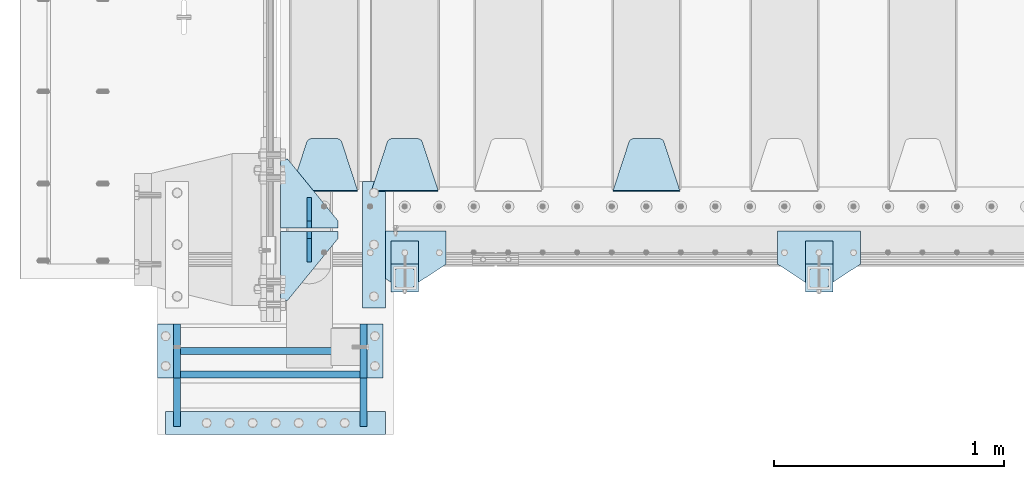
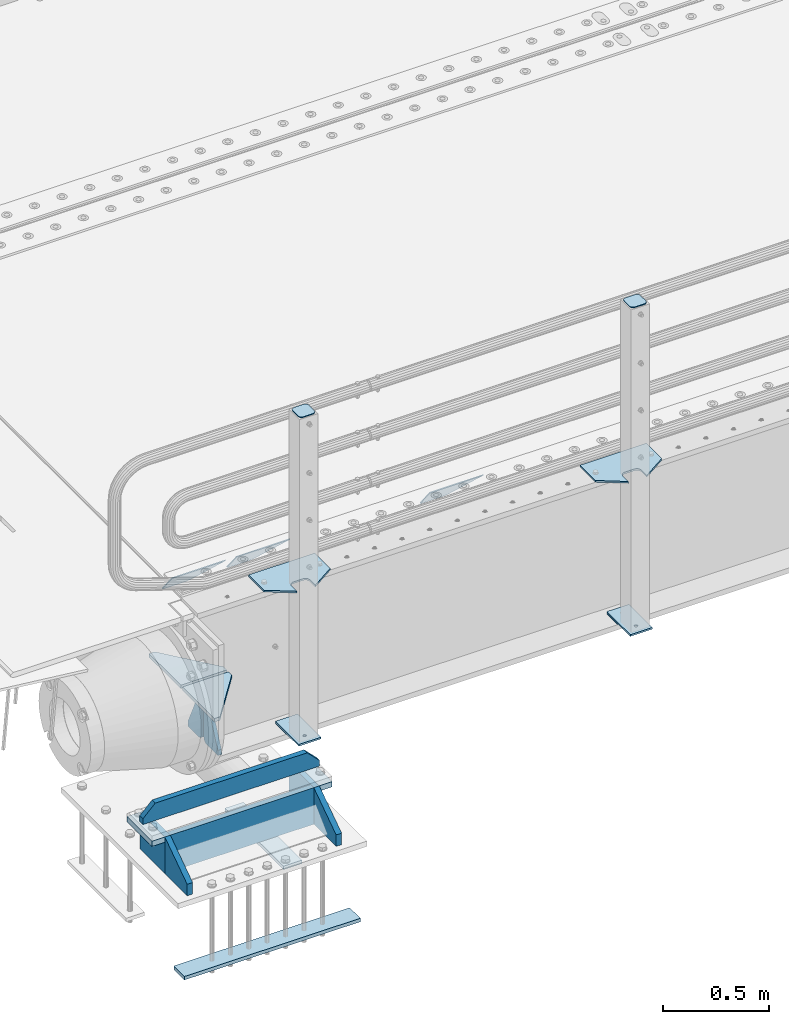
# One storey, part 154 of 193: 25 plates.
"""IFC2X3 building model written with IfcOpenShell, lengths in millimetres."""

from ifc_helpers import new_model, si_unit, frame, origin_with_axes, place, context, subcontext, project, spatial, faceted_brep, material, type_object, element, save


model = new_model("IFC2X3")

# Units and contexts
model_context = context("Model", 3, precision=1e-05, world=origin_with_axes())
body_context = subcontext(model_context, "Body", "Model", "MODEL_VIEW")
ifc_project = project(units=[si_unit("LENGTHUNIT", "METRE", prefix="MILLI"), si_unit("AREAUNIT", "SQUARE_METRE"), si_unit("VOLUMEUNIT", "CUBIC_METRE"), si_unit("MASSUNIT", "GRAM", prefix="KILO"), si_unit("TIMEUNIT", "SECOND"), si_unit("PLANEANGLEUNIT", "RADIAN"), si_unit("SOLIDANGLEUNIT", "STERADIAN"), si_unit("THERMODYNAMICTEMPERATUREUNIT", "DEGREE_CELSIUS"), si_unit("LUMINOUSINTENSITYUNIT", "LUMEN")], contexts=[model_context])

# Site, building, storey
site_placement = place(None, origin_with_axes())
site = spatial("IfcSite", under=ifc_project, at=site_placement, CompositionType="ELEMENT")
building_placement = place(site_placement, origin_with_axes())
building = spatial("IfcBuilding", under=site, at=building_placement, Name="Standard", CompositionType="ELEMENT")
storey_placement = place(building_placement, origin_with_axes())
storey = spatial("IfcBuildingStorey", under=building, at=storey_placement, Name="Undefined", CompositionType="ELEMENT", Elevation=0.0)

# Plates
ifc_material_1 = material(Name="STEEL/S355N")
plate_type_1 = type_object("IfcPlateType", PredefinedType="NOTDEFINED")
plate_1_placement = place(storey_placement, frame((-40705.0, 24168.232233047, -1.76776695296758), z_axis=(0.0, 0.707106781186547, -0.707106781186548), x_axis=(-1.0, 0.0, 0.0)))
element("IfcPlate", 1, at=plate_1_placement, inside=storey, type_object=plate_type_1, material=ifc_material_1, context=body_context, shape_type="Brep", body=[
    faceted_brep([(0.0, -2.5, 0.0), (69.345504679477, -2.50000000000364, 300.171731424831), (69.345504679477, 2.49999999999636, 300.171731424831), (0.0, 2.5, 0.0), (70.9274061199576, -2.50000000000364, 304.897442415397), (70.9274061199576, 2.49999999999636, 304.897442415397), (73.3818627772307, -2.50000000000364, 309.234538108529), (73.3818627772307, 2.49999999999636, 309.234538108529), (76.6187032999551, -2.50000000000728, 313.023683126103), (76.6187032999551, 2.49999999999636, 313.023683126103), (80.5190132704993, -2.50000000000364, 316.125672595372), (80.5190132704993, 2.49999999999636, 316.125672595368), (84.9395038596849, -2.50000000000364, 318.426546230472), (84.9395038596849, 2.49999999999636, 318.426546230476), (89.7177759439219, -2.50000000000364, 319.841774983273), (89.7177759439219, 2.49999999999636, 319.841774983277), (94.678286292652, -2.50000000000364, 320.319366455074), (94.678286292652, 2.49999999999636, 320.319366455074), (195.321713707348, -2.50000000000364, 320.319366455074), (195.321713707348, 2.49999999999636, 320.319366455074), (200.282224056078, -2.50000000000364, 319.841774983273), (200.282224056078, 2.49999999999636, 319.841774983277), (205.060496140315, -2.50000000000364, 318.426546230472), (205.060496140315, 2.49999999999636, 318.426546230472), (209.480986729501, -2.50000000000364, 316.125672595372), (209.480986729501, 2.49999999999636, 316.125672595368), (213.381296700045, -2.50000000000728, 313.023683126103), (213.381296700045, 2.49999999999272, 313.023683126103), (216.618137222769, -2.50000000000364, 309.234538108525), (216.618137222769, 2.49999999999636, 309.234538108522), (219.072593880042, -2.50000000000364, 304.897442415397), (219.072593880042, 2.49999999999636, 304.897442415397), (220.654495320523, -2.50000000000364, 300.171731424831), (220.654495320523, 2.49999999999636, 300.171731424831), (290.0, -2.50000000000364, 0.0), (290.0, 2.49999999999636, 0.0)], [[[0, 1, 2, 3]], [[1, 4, 5, 2]], [[4, 6, 7, 5]], [[6, 8, 9, 7]], [[8, 10, 11, 9]], [[10, 12, 13, 11]], [[12, 14, 15, 13]], [[14, 16, 17, 15]], [[16, 18, 19, 17]], [[18, 20, 21, 19]], [[20, 22, 23, 21]], [[22, 24, 25, 23]], [[24, 26, 27, 25]], [[26, 28, 29, 27]], [[28, 30, 31, 29]], [[30, 32, 33, 31]], [[32, 34, 35, 33]], [[34, 0, 3, 35]], [[5, 7, 9, 11, 13, 15, 17, 19, 21, 23, 25, 27, 29, 31, 33, 35, 3, 2]], [[34, 32, 30, 28, 26, 24, 22, 20, 18, 16, 14, 12, 10, 8, 6, 4, 1, 0]]]),
])
plate_2_placement = place(storey_placement, frame((-41755.0, 24168.232233047, -1.76776695296758), z_axis=(0.0, 0.707106781186547, -0.707106781186548), x_axis=(-1.0, 0.0, 0.0)))
element("IfcPlate", 2, at=plate_2_placement, inside=storey, type_object=plate_type_1, material=ifc_material_1, context=body_context, shape_type="Brep", body=[
    faceted_brep([(0.0, -2.5, 0.0), (69.345504679477, -2.50000000000364, 300.171731424831), (69.345504679477, 2.49999999999636, 300.171731424831), (0.0, 2.5, 0.0), (70.9274061199576, -2.50000000000364, 304.897442415397), (70.9274061199576, 2.49999999999636, 304.897442415397), (73.3818627772307, -2.50000000000364, 309.234538108529), (73.3818627772307, 2.49999999999636, 309.234538108529), (76.6187032999551, -2.50000000000728, 313.023683126103), (76.6187032999551, 2.49999999999636, 313.023683126103), (80.5190132704993, -2.50000000000364, 316.125672595372), (80.5190132704993, 2.49999999999636, 316.125672595368), (84.9395038596849, -2.50000000000364, 318.426546230472), (84.9395038596849, 2.49999999999636, 318.426546230476), (89.7177759439219, -2.50000000000364, 319.841774983273), (89.7177759439219, 2.49999999999636, 319.841774983277), (94.678286292652, -2.50000000000364, 320.319366455074), (94.678286292652, 2.49999999999636, 320.319366455074), (195.321713707348, -2.50000000000364, 320.319366455074), (195.321713707348, 2.49999999999636, 320.319366455074), (200.282224056078, -2.50000000000364, 319.841774983273), (200.282224056078, 2.49999999999636, 319.841774983277), (205.060496140315, -2.50000000000364, 318.426546230472), (205.060496140315, 2.49999999999636, 318.426546230472), (209.480986729501, -2.50000000000364, 316.125672595372), (209.480986729501, 2.49999999999636, 316.125672595368), (213.381296700045, -2.50000000000728, 313.023683126103), (213.381296700045, 2.49999999999272, 313.023683126103), (216.618137222769, -2.50000000000364, 309.234538108525), (216.618137222769, 2.49999999999636, 309.234538108522), (219.072593880042, -2.50000000000364, 304.897442415397), (219.072593880042, 2.49999999999636, 304.897442415397), (220.654495320523, -2.50000000000364, 300.171731424831), (220.654495320523, 2.49999999999636, 300.171731424831), (290.0, -2.50000000000364, 0.0), (290.0, 2.49999999999636, 0.0)], [[[0, 1, 2, 3]], [[1, 4, 5, 2]], [[4, 6, 7, 5]], [[6, 8, 9, 7]], [[8, 10, 11, 9]], [[10, 12, 13, 11]], [[12, 14, 15, 13]], [[14, 16, 17, 15]], [[16, 18, 19, 17]], [[18, 20, 21, 19]], [[20, 22, 23, 21]], [[22, 24, 25, 23]], [[24, 26, 27, 25]], [[26, 28, 29, 27]], [[28, 30, 31, 29]], [[30, 32, 33, 31]], [[32, 34, 35, 33]], [[34, 0, 3, 35]], [[5, 7, 9, 11, 13, 15, 17, 19, 21, 23, 25, 27, 29, 31, 33, 35, 3, 2]], [[34, 32, 30, 28, 26, 24, 22, 20, 18, 16, 14, 12, 10, 8, 6, 4, 1, 0]]]),
])
plate_3_placement = place(storey_placement, frame((-42105.0, 24168.232233047, -1.76776695296758), z_axis=(0.0, 0.707106781186547, -0.707106781186548), x_axis=(-1.0, 0.0, 0.0)))
element("IfcPlate", 3, at=plate_3_placement, inside=storey, type_object=plate_type_1, material=ifc_material_1, context=body_context, shape_type="Brep", body=[
    faceted_brep([(0.0, -2.5, 0.0), (69.345504679477, -2.50000000000364, 300.171731424831), (69.345504679477, 2.49999999999636, 300.171731424831), (0.0, 2.5, 0.0), (70.9274061199576, -2.50000000000364, 304.897442415397), (70.9274061199576, 2.49999999999636, 304.897442415397), (73.3818627772307, -2.50000000000364, 309.234538108529), (73.3818627772307, 2.49999999999636, 309.234538108529), (76.6187032999551, -2.50000000000728, 313.023683126103), (76.6187032999551, 2.49999999999636, 313.023683126103), (80.5190132704993, -2.50000000000364, 316.125672595372), (80.5190132704993, 2.49999999999636, 316.125672595368), (84.9395038596849, -2.50000000000364, 318.426546230472), (84.9395038596849, 2.49999999999636, 318.426546230476), (89.7177759439219, -2.50000000000364, 319.841774983273), (89.7177759439219, 2.49999999999636, 319.841774983277), (94.678286292652, -2.50000000000364, 320.319366455074), (94.678286292652, 2.49999999999636, 320.319366455074), (195.321713707348, -2.50000000000364, 320.319366455074), (195.321713707348, 2.49999999999636, 320.319366455074), (200.282224056078, -2.50000000000364, 319.841774983273), (200.282224056078, 2.49999999999636, 319.841774983277), (205.060496140315, -2.50000000000364, 318.426546230472), (205.060496140315, 2.49999999999636, 318.426546230472), (209.480986729501, -2.50000000000364, 316.125672595372), (209.480986729501, 2.49999999999636, 316.125672595368), (213.381296700045, -2.50000000000728, 313.023683126103), (213.381296700045, 2.49999999999272, 313.023683126103), (216.618137222769, -2.50000000000364, 309.234538108525), (216.618137222769, 2.49999999999636, 309.234538108522), (219.072593880042, -2.50000000000364, 304.897442415397), (219.072593880042, 2.49999999999636, 304.897442415397), (220.654495320523, -2.50000000000364, 300.171731424831), (220.654495320523, 2.49999999999636, 300.171731424831), (290.0, -2.50000000000364, 0.0), (290.0, 2.49999999999636, 0.0)], [[[0, 1, 2, 3]], [[1, 4, 5, 2]], [[4, 6, 7, 5]], [[6, 8, 9, 7]], [[8, 10, 11, 9]], [[10, 12, 13, 11]], [[12, 14, 15, 13]], [[14, 16, 17, 15]], [[16, 18, 19, 17]], [[18, 20, 21, 19]], [[20, 22, 23, 21]], [[22, 24, 25, 23]], [[24, 26, 27, 25]], [[26, 28, 29, 27]], [[28, 30, 31, 29]], [[30, 32, 33, 31]], [[32, 34, 35, 33]], [[34, 0, 3, 35]], [[5, 7, 9, 11, 13, 15, 17, 19, 21, 23, 25, 27, 29, 31, 33, 35, 3, 2]], [[34, 32, 30, 28, 26, 24, 22, 20, 18, 16, 14, 12, 10, 8, 6, 4, 1, 0]]]),
])
plate_type_2 = type_object("IfcPlateType", PredefinedType="NOTDEFINED")
for number, where, z_axis, x_axis in (
    (4, (-42190.0, 24008.0, -515.0), (0.0, 1.0, 0.0), (-1.0, 0.0, 0.0)),
    (5, (-42190.0, 23992.0, -515.0), (0.0, -1.0, 0.0), (-1.0, 0.0, 0.0)),
):
    element("IfcPlate", number, at=place(storey_placement, frame(where, z_axis=z_axis, x_axis=x_axis)), inside=storey, type_object=plate_type_2, material=ifc_material_1, context=body_context, shape_type="Brep", body=[
        faceted_brep([(0.0, -10.0, 0.0), (0.0, -10.0, 30.0), (0.0, 10.0, 30.0), (0.0, 10.0, 0.0), (220.0, -10.0, 300.0), (220.0, 10.0, 300.0), (250.0, -10.0, 300.0), (250.0, 10.0, 300.0), (250.0, -10.0, 0.0), (250.0, 10.0, 0.0)], [[[0, 1, 2, 3]], [[1, 4, 5, 2]], [[4, 6, 7, 5]], [[6, 8, 9, 7]], [[8, 0, 3, 9]], [[5, 7, 9, 3, 2]], [[8, 6, 4, 1, 0]]]),
    ])
plate_type_3 = type_object("IfcPlateType", PredefinedType="NOTDEFINED")
for number, where, z_axis, x_axis in (
    (6, (-42315.0, 23860.0, -860.0), (0.0, 0.0, 1.0), (0.0, 1.0, 0.0)),
    (7, (-42315.0, 24140.0, -860.0), (0.0, 0.0, 1.0), (0.0, -1.0, 0.0)),
):
    element("IfcPlate", number, at=place(storey_placement, frame(where, z_axis=z_axis, x_axis=x_axis)), inside=storey, type_object=plate_type_3, material=ifc_material_1, context=body_context, shape_type="Brep", body=[
        faceted_brep([(0.0, -10.0, 0.0), (0.0, -10.0, 30.0), (0.0, 10.0, 30.0), (0.0, 10.0, 0.0), (102.0, -10.0, 250.0), (102.0, 10.0, 250.0), (132.0, -10.0, 250.0), (132.0, 10.0, 250.0), (132.0, -10.0, 30.0), (132.0, 10.0, 30.0), (131.544232590368, -10.0, 24.790554669992), (131.544232590368, 10.0, 24.790554669992), (130.190778623579, -10.0, 19.7393957002299), (130.190778623579, 10.0, 19.7393957002299), (127.980762113533, -10.0, 15.0), (127.980762113533, 10.0, 15.0), (124.98133329357, -10.0, 10.7163717094038), (124.98133329357, 10.0, 10.7163717094038), (121.283628290596, -10.0, 7.01866670643062), (121.283628290596, 10.0, 7.01866670643062), (117.0, -10.0, 4.01923788646684), (117.0, 10.0, 4.01923788646684), (112.260604299769, -10.0, 1.80922137642278), (112.260604299769, 10.0, 1.80922137642278), (107.209445330009, -10.0, 0.455767409633722), (107.209445330009, 10.0, 0.455767409633722), (102.0, -10.0, 0.0), (102.0, 10.0, 0.0)], [[[0, 1, 2, 3]], [[1, 4, 5, 2]], [[4, 6, 7, 5]], [[6, 8, 9, 7]], [[8, 10, 11, 9]], [[10, 12, 13, 11]], [[12, 14, 15, 13]], [[14, 16, 17, 15]], [[16, 18, 19, 17]], [[18, 20, 21, 19]], [[20, 22, 23, 21]], [[22, 24, 25, 23]], [[24, 26, 27, 25]], [[26, 0, 3, 27]], [[5, 7, 9, 11, 13, 15, 17, 19, 21, 23, 25, 27, 3, 2]], [[26, 24, 22, 20, 18, 16, 14, 12, 10, 8, 6, 4, 1, 0]]]),
    ])
ifc_material_2 = material(Name="STEEL/S355J2")
plate_type_4 = type_object("IfcPlateType", PredefinedType="NOTDEFINED")
plate_4_placement = place(storey_placement, frame((-39920.0, 23995.0, 5.00000000004911), z_axis=(0.0, -1.0, 0.0), x_axis=(-1.0, 0.0, 0.0)))
element("IfcPlate", 8, at=plate_4_placement, inside=storey, type_object=plate_type_4, material=ifc_material_2, context=body_context, shape_type="Brep", body=[
    faceted_brep([(0.0, -5.0, 0.0), (2.31396552408114e-06, -5.0, 145.0), (2.31396552408114e-06, 5.0, 145.0), (0.0, 5.0, 0.0), (130.0, -5.0, 230.0), (130.0, 5.0, 230.0), (130.0, -5.0, 180.0), (130.0, 5.0, 180.0), (130.48036798992, -5.0, 175.122741949595), (130.48036798992, 5.0, 175.122741949595), (131.903011687216, -5.0, 170.432914190871), (131.903011687216, 5.0, 170.432914190871), (134.213259692435, -5.0, 166.110744174512), (134.213259692435, 5.0, 166.110744174512), (137.322330470335, -5.0, 162.322330470335), (137.322330470335, 5.0, 162.322330470335), (141.110744174512, -5.0, 159.213259692435), (141.110744174512, 5.0, 159.213259692435), (145.432914190871, -5.0, 156.903011687216), (145.432914190871, 5.0, 156.903011687216), (150.122741949595, -5.0, 155.48036798992), (150.122741949595, 5.0, 155.48036798992), (155.0, -5.0, 155.0), (155.0, 5.0, 155.0), (205.0, -5.0, 155.0), (205.0, 5.0, 155.0), (209.877258050405, -5.0, 155.48036798992), (209.877258050405, 5.0, 155.48036798992), (214.567085809129, -5.0, 156.903011687216), (214.567085809129, 5.0, 156.903011687216), (218.889255825488, -5.0, 159.213259692435), (218.889255825488, 5.0, 159.213259692435), (222.677669529665, -5.0, 162.322330470335), (222.677669529665, 5.0, 162.322330470335), (225.786740307565, -5.0, 166.110744174512), (225.786740307565, 5.0, 166.110744174512), (228.096988312784, -5.0, 170.432914190871), (228.096988312784, 5.0, 170.432914190871), (229.51963201008, -5.0, 175.122741949595), (229.51963201008, 5.0, 175.122741949595), (230.0, -5.0, 180.0), (230.0, 5.0, 180.0), (230.0, -5.0, 230.0), (230.0, 5.0, 230.0), (360.0, -5.0, 145.0), (360.0, 5.0, 145.0), (360.0, -5.0, -7.27595761418343e-12), (360.0, 5.0, -7.27595761418343e-12)], [[[0, 1, 2, 3]], [[1, 4, 5, 2]], [[4, 6, 7, 5]], [[6, 8, 9, 7]], [[8, 10, 11, 9]], [[10, 12, 13, 11]], [[12, 14, 15, 13]], [[14, 16, 17, 15]], [[16, 18, 19, 17]], [[18, 20, 21, 19]], [[20, 22, 23, 21]], [[22, 24, 25, 23]], [[24, 26, 27, 25]], [[26, 28, 29, 27]], [[28, 30, 31, 29]], [[30, 32, 33, 31]], [[32, 34, 35, 33]], [[34, 36, 37, 35]], [[36, 38, 39, 37]], [[38, 40, 41, 39]], [[40, 42, 43, 41]], [[42, 44, 45, 43]], [[44, 46, 47, 45]], [[46, 0, 3, 47]], [[5, 7, 9, 11, 13, 15, 17, 19, 21, 23, 25, 27, 29, 31, 33, 35, 37, 39, 41, 43, 45, 47, 3, 2]], [[46, 44, 42, 40, 38, 36, 34, 32, 30, 28, 26, 24, 22, 20, 18, 16, 14, 12, 10, 8, 6, 4, 1, 0]]]),
])
plate_5_placement = place(storey_placement, frame((-41720.0, 23995.0, 5.00000000004911), z_axis=(0.0, -1.0, 0.0), x_axis=(-1.0, 0.0, 0.0)))
element("IfcPlate", 9, at=plate_5_placement, inside=storey, type_object=plate_type_4, material=ifc_material_2, context=body_context, shape_type="Brep", body=[
    faceted_brep([(0.0, -5.0, 0.0), (2.31396552408114e-06, -5.0, 145.0), (2.31396552408114e-06, 5.0, 145.0), (0.0, 5.0, 0.0), (130.0, -5.0, 230.0), (130.0, 5.0, 230.0), (130.0, -5.0, 180.0), (130.0, 5.0, 180.0), (130.48036798992, -5.0, 175.122741949595), (130.48036798992, 5.0, 175.122741949595), (131.903011687216, -5.0, 170.432914190871), (131.903011687216, 5.0, 170.432914190871), (134.213259692435, -5.0, 166.110744174512), (134.213259692435, 5.0, 166.110744174512), (137.322330470335, -5.0, 162.322330470335), (137.322330470335, 5.0, 162.322330470335), (141.110744174512, -5.0, 159.213259692435), (141.110744174512, 5.0, 159.213259692435), (145.432914190871, -5.0, 156.903011687216), (145.432914190871, 5.0, 156.903011687216), (150.122741949595, -5.0, 155.48036798992), (150.122741949595, 5.0, 155.48036798992), (155.0, -5.0, 155.0), (155.0, 5.0, 155.0), (205.0, -5.0, 155.0), (205.0, 5.0, 155.0), (209.877258050405, -5.0, 155.48036798992), (209.877258050405, 5.0, 155.48036798992), (214.567085809129, -5.0, 156.903011687216), (214.567085809129, 5.0, 156.903011687216), (218.889255825488, -5.0, 159.213259692435), (218.889255825488, 5.0, 159.213259692435), (222.677669529665, -5.0, 162.322330470335), (222.677669529665, 5.0, 162.322330470335), (225.786740307565, -5.0, 166.110744174512), (225.786740307565, 5.0, 166.110744174512), (228.096988312784, -5.0, 170.432914190871), (228.096988312784, 5.0, 170.432914190871), (229.51963201008, -5.0, 175.122741949595), (229.51963201008, 5.0, 175.122741949595), (230.0, -5.0, 180.0), (230.0, 5.0, 180.0), (230.0, -5.0, 230.0), (230.0, 5.0, 230.0), (360.0, -5.0, 145.0), (360.0, 5.0, 145.0), (360.0, -5.0, -7.27595761418343e-12), (360.0, 5.0, -7.27595761418343e-12)], [[[0, 1, 2, 3]], [[1, 4, 5, 2]], [[4, 6, 7, 5]], [[6, 8, 9, 7]], [[8, 10, 11, 9]], [[10, 12, 13, 11]], [[12, 14, 15, 13]], [[14, 16, 17, 15]], [[16, 18, 19, 17]], [[18, 20, 21, 19]], [[20, 22, 23, 21]], [[22, 24, 25, 23]], [[24, 26, 27, 25]], [[26, 28, 29, 27]], [[28, 30, 31, 29]], [[30, 32, 33, 31]], [[32, 34, 35, 33]], [[34, 36, 37, 35]], [[36, 38, 39, 37]], [[38, 40, 41, 39]], [[40, 42, 43, 41]], [[42, 44, 45, 43]], [[44, 46, 47, 45]], [[46, 0, 3, 47]], [[5, 7, 9, 11, 13, 15, 17, 19, 21, 23, 25, 27, 29, 31, 33, 35, 37, 39, 41, 43, 45, 47, 3, 2]], [[46, 44, 42, 40, 38, 36, 34, 32, 30, 28, 26, 24, 22, 20, 18, 16, 14, 12, 10, 8, 6, 4, 1, 0]]]),
])
plate_type_5 = type_object("IfcPlateType", PredefinedType="NOTDEFINED")
for number, where, z_axis, x_axis in (
    (10, (-40040.0000000001, 23949.9999999998, -850.000000000002), (0.0, -1.0, 0.0), (-1.0, 0.0, 0.0)),
    (11, (-41840.0000000001, 23949.9999999998, -850.000000000002), (0.0, -1.0, 0.0), (-1.0, 0.0, 0.0)),
):
    element("IfcPlate", number, at=place(storey_placement, frame(where, z_axis=z_axis, x_axis=x_axis)), inside=storey, type_object=plate_type_5, material=ifc_material_2, context=body_context, shape_type="Brep", body=[
        faceted_brep([(53.6360389691836, -5.0, 176.363961030467), (53.6360389691836, 5.0, 176.363961030467), (59.9999999998618, 5.0, 178.999999999789), (59.9999999998618, -5.0, 178.999999999789), (66.3639610305399, 5.0, 176.363961030467), (66.3639610305399, -5.0, 176.363961030467), (68.9999999998618, 5.0, 169.999999999789), (68.9999999998618, -5.0, 169.999999999789), (66.3639610305399, 5.0, 163.636038969111), (66.3639610305399, -5.0, 163.636038969111), (59.9999999998618, 5.0, 160.999999999789), (59.9999999998618, -5.0, 160.999999999789), (53.6360389691836, 5.0, 163.636038969111), (53.6360389691836, -5.0, 163.636038969111), (50.9999999998618, 5.0, 169.999999999789), (50.9999999998618, -5.0, 169.999999999789), (120.0, -5.0, 0.0), (120.0, -5.0, 220.0), (0.0, -5.0, 220.0), (0.0, -5.0, 0.0), (0.0, 5.0, 0.0), (120.0, 5.0, 0.0), (120.0, 5.0, 220.0), (0.0, 5.0, 220.0)], [[[0, 1, 2, 3]], [[3, 2, 4, 5]], [[5, 4, 6, 7]], [[7, 6, 8, 9]], [[9, 8, 10, 11]], [[11, 10, 12, 13]], [[13, 12, 14, 15]], [[15, 14, 1, 0]], [[16, 17, 18, 19], [11, 13, 15, 0, 3, 5, 7, 9]], [[16, 19, 20, 21]], [[17, 16, 21, 22]], [[18, 17, 22, 23]], [[19, 18, 23, 20]], [[22, 21, 20, 23], [2, 1, 14, 12, 10, 8, 6, 4]]]),
    ])
plate_type_6 = type_object("IfcPlateType", PredefinedType="NOTDEFINED")
plate_6_placement = place(storey_placement, frame((-40144.0000000001, 23833.9999999998, 1012.50000000001), z_axis=(0.0, -1.0, 0.0), x_axis=(1.0, 0.0, 0.0)))
element("IfcPlate", 12, at=plate_6_placement, inside=storey, type_object=plate_type_6, material=ifc_material_2, context=body_context, shape_type="Brep", body=[
    faceted_brep([(0.0, -2.5, 19.0), (0.0, -2.5, 69.0), (0.0, 2.5, 69.0), (0.0, 2.5, 19.0), (0.476369668544066, -2.5, 73.2278977451715), (0.476369668544066, 2.5, 73.2278977451715), (1.88159150985302, -2.5, 77.2437910432345), (1.88159150985302, 2.5, 77.2437910432345), (4.14520183310742, -2.5, 80.8463062353148), (4.14520183310742, 2.5, 80.8463062353148), (7.15369376468516, -2.5, 83.8547981668926), (7.15369376468516, 2.5, 83.8547981668926), (10.7562089567655, -2.5, 86.118408490147), (10.7562089567655, 2.5, 86.118408490147), (14.7721022548285, -2.5, 87.5236303314559), (14.7721022548285, 2.5, 87.5236303314559), (19.0, -2.5, 88.0), (19.0, 2.5, 88.0), (69.0, -2.5, 88.0), (69.0, 2.5, 88.0), (73.2278977451715, -2.5, 87.5236303314559), (73.2278977451715, 2.5, 87.5236303314559), (77.2437910432345, -2.5, 86.118408490147), (77.2437910432345, 2.5, 86.118408490147), (80.8463062353148, -2.5, 83.8547981668926), (80.8463062353148, 2.5, 83.8547981668926), (83.8547981668926, -2.5, 80.8463062353148), (83.8547981668926, 2.5, 80.8463062353148), (86.118408490147, -2.5, 77.2437910432345), (86.118408490147, 2.5, 77.2437910432345), (87.5236303314559, -2.5, 73.2278977451715), (87.5236303314559, 2.5, 73.2278977451715), (88.0, -2.5, 69.0), (88.0, 2.5, 69.0), (88.0, -2.5, 19.0), (88.0, 2.5, 19.0), (87.5236303314559, -2.5, 14.7721022548285), (87.5236303314559, 2.5, 14.7721022548285), (86.118408490147, -2.5, 10.7562089567655), (86.118408490147, 2.5, 10.7562089567655), (83.8547981668926, -2.5, 7.15369376468516), (83.8547981668926, 2.5, 7.15369376468516), (80.8463062353148, -2.5, 4.14520183310742), (80.8463062353148, 2.5, 4.14520183310742), (77.2437910432345, -2.5, 1.88159150985302), (77.2437910432345, 2.5, 1.88159150985302), (73.2278977451715, -2.5, 0.476369668544066), (73.2278977451715, 2.5, 0.476369668544066), (69.0, -2.5, 0.0), (69.0, 2.5, 0.0), (19.0, -2.5, 0.0), (19.0, 2.5, 0.0), (14.7721022548285, -2.5, 0.476369668544066), (14.7721022548285, 2.5, 0.476369668544066), (10.7562089567655, -2.5, 1.88159150985302), (10.7562089567655, 2.5, 1.88159150985302), (7.15369376468516, -2.5, 4.14520183310742), (7.15369376468516, 2.5, 4.14520183310742), (4.14520183310742, -2.5, 7.15369376468516), (4.14520183310742, 2.5, 7.15369376468516), (1.88159150985302, -2.5, 10.7562089567655), (1.88159150985302, 2.5, 10.7562089567655), (0.476369668544066, -2.5, 14.7721022548285), (0.476369668544066, 2.5, 14.7721022548285)], [[[0, 1, 2, 3]], [[1, 4, 5, 2]], [[4, 6, 7, 5]], [[6, 8, 9, 7]], [[8, 10, 11, 9]], [[10, 12, 13, 11]], [[12, 14, 15, 13]], [[14, 16, 17, 15]], [[16, 18, 19, 17]], [[18, 20, 21, 19]], [[20, 22, 23, 21]], [[22, 24, 25, 23]], [[24, 26, 27, 25]], [[26, 28, 29, 27]], [[28, 30, 31, 29]], [[30, 32, 33, 31]], [[32, 34, 35, 33]], [[34, 36, 37, 35]], [[36, 38, 39, 37]], [[38, 40, 41, 39]], [[40, 42, 43, 41]], [[42, 44, 45, 43]], [[44, 46, 47, 45]], [[46, 48, 49, 47]], [[48, 50, 51, 49]], [[50, 52, 53, 51]], [[52, 54, 55, 53]], [[54, 56, 57, 55]], [[56, 58, 59, 57]], [[58, 60, 61, 59]], [[60, 62, 63, 61]], [[62, 0, 3, 63]], [[5, 7, 9, 11, 13, 15, 17, 19, 21, 23, 25, 27, 29, 31, 33, 35, 37, 39, 41, 43, 45, 47, 49, 51, 53, 55, 57, 59, 61, 63, 3, 2]], [[62, 60, 58, 56, 54, 52, 50, 48, 46, 44, 42, 40, 38, 36, 34, 32, 30, 28, 26, 24, 22, 20, 18, 16, 14, 12, 10, 8, 6, 4, 1, 0]]]),
])
plate_7_placement = place(storey_placement, frame((-41944.0000000001, 23833.9999999998, 1012.50000000001), z_axis=(0.0, -1.0, 0.0), x_axis=(1.0, 0.0, 0.0)))
element("IfcPlate", 13, at=plate_7_placement, inside=storey, type_object=plate_type_6, material=ifc_material_2, context=body_context, shape_type="Brep", body=[
    faceted_brep([(0.0, -2.5, 19.0), (0.0, -2.5, 69.0), (0.0, 2.5, 69.0), (0.0, 2.5, 19.0), (0.476369668544066, -2.5, 73.2278977451715), (0.476369668544066, 2.5, 73.2278977451715), (1.88159150985302, -2.5, 77.2437910432345), (1.88159150985302, 2.5, 77.2437910432345), (4.14520183310742, -2.5, 80.8463062353148), (4.14520183310742, 2.5, 80.8463062353148), (7.15369376468516, -2.5, 83.8547981668926), (7.15369376468516, 2.5, 83.8547981668926), (10.7562089567655, -2.5, 86.118408490147), (10.7562089567655, 2.5, 86.118408490147), (14.7721022548285, -2.5, 87.5236303314559), (14.7721022548285, 2.5, 87.5236303314559), (19.0, -2.5, 88.0), (19.0, 2.5, 88.0), (69.0, -2.5, 88.0), (69.0, 2.5, 88.0), (73.2278977451715, -2.5, 87.5236303314559), (73.2278977451715, 2.5, 87.5236303314559), (77.2437910432345, -2.5, 86.118408490147), (77.2437910432345, 2.5, 86.118408490147), (80.8463062353148, -2.5, 83.8547981668926), (80.8463062353148, 2.5, 83.8547981668926), (83.8547981668926, -2.5, 80.8463062353148), (83.8547981668926, 2.5, 80.8463062353148), (86.118408490147, -2.5, 77.2437910432345), (86.118408490147, 2.5, 77.2437910432345), (87.5236303314559, -2.5, 73.2278977451715), (87.5236303314559, 2.5, 73.2278977451715), (88.0, -2.5, 69.0), (88.0, 2.5, 69.0), (88.0, -2.5, 19.0), (88.0, 2.5, 19.0), (87.5236303314559, -2.5, 14.7721022548285), (87.5236303314559, 2.5, 14.7721022548285), (86.118408490147, -2.5, 10.7562089567655), (86.118408490147, 2.5, 10.7562089567655), (83.8547981668926, -2.5, 7.15369376468516), (83.8547981668926, 2.5, 7.15369376468516), (80.8463062353148, -2.5, 4.14520183310742), (80.8463062353148, 2.5, 4.14520183310742), (77.2437910432345, -2.5, 1.88159150985302), (77.2437910432345, 2.5, 1.88159150985302), (73.2278977451715, -2.5, 0.476369668544066), (73.2278977451715, 2.5, 0.476369668544066), (69.0, -2.5, 0.0), (69.0, 2.5, 0.0), (19.0, -2.5, 0.0), (19.0, 2.5, 0.0), (14.7721022548285, -2.5, 0.476369668544066), (14.7721022548285, 2.5, 0.476369668544066), (10.7562089567655, -2.5, 1.88159150985302), (10.7562089567655, 2.5, 1.88159150985302), (7.15369376468516, -2.5, 4.14520183310742), (7.15369376468516, 2.5, 4.14520183310742), (4.14520183310742, -2.5, 7.15369376468516), (4.14520183310742, 2.5, 7.15369376468516), (1.88159150985302, -2.5, 10.7562089567655), (1.88159150985302, 2.5, 10.7562089567655), (0.476369668544066, -2.5, 14.7721022548285), (0.476369668544066, 2.5, 14.7721022548285)], [[[0, 1, 2, 3]], [[1, 4, 5, 2]], [[4, 6, 7, 5]], [[6, 8, 9, 7]], [[8, 10, 11, 9]], [[10, 12, 13, 11]], [[12, 14, 15, 13]], [[14, 16, 17, 15]], [[16, 18, 19, 17]], [[18, 20, 21, 19]], [[20, 22, 23, 21]], [[22, 24, 25, 23]], [[24, 26, 27, 25]], [[26, 28, 29, 27]], [[28, 30, 31, 29]], [[30, 32, 33, 31]], [[32, 34, 35, 33]], [[34, 36, 37, 35]], [[36, 38, 39, 37]], [[38, 40, 41, 39]], [[40, 42, 43, 41]], [[42, 44, 45, 43]], [[44, 46, 47, 45]], [[46, 48, 49, 47]], [[48, 50, 51, 49]], [[50, 52, 53, 51]], [[52, 54, 55, 53]], [[54, 56, 57, 55]], [[56, 58, 59, 57]], [[58, 60, 61, 59]], [[60, 62, 63, 61]], [[62, 0, 3, 63]], [[5, 7, 9, 11, 13, 15, 17, 19, 21, 23, 25, 27, 29, 31, 33, 35, 37, 39, 41, 43, 45, 47, 49, 51, 53, 55, 57, 59, 61, 63, 3, 2]], [[62, 60, 58, 56, 54, 52, 50, 48, 46, 44, 42, 40, 38, 36, 34, 32, 30, 28, 26, 24, 22, 20, 18, 16, 14, 12, 10, 8, 6, 4, 1, 0]]]),
])
plate_type_7 = type_object("IfcPlateType", PredefinedType="NOTDEFINED")
for number, where, z_axis, x_axis in (
    (14, (-40040.0000000001, 23949.9999999998, -857.500000000002), (0.0, -1.0, 0.0), (-1.0, 0.0, 0.0)),
    (15, (-41840.0000000001, 23949.9999999998, -857.500000000002), (0.0, -1.0, 0.0), (-1.0, 0.0, 0.0)),
):
    element("IfcPlate", number, at=place(storey_placement, frame(where, z_axis=z_axis, x_axis=x_axis)), inside=storey, type_object=plate_type_7, material=ifc_material_2, context=body_context, shape_type="Brep", body=[
        faceted_brep([(0.0, -2.5, 0.0), (0.0, -2.5, 100.0), (0.0, 2.5, 100.0), (0.0, 2.5, 0.0), (120.0, -2.5, 100.0), (120.0, 2.5, 100.0), (120.0, -2.5, 0.0), (120.0, 2.5, 0.0)], [[[0, 1, 2, 3]], [[1, 4, 5, 2]], [[4, 6, 7, 5]], [[6, 0, 3, 7]], [[5, 7, 3, 2]], [[6, 4, 1, 0]]]),
    ])
plate_type_8 = type_object("IfcPlateType", PredefinedType="NOTDEFINED")
plate_8_placement = place(storey_placement, frame((-42084.0, 23660.0000014662, -1468.0), z_axis=(0.0, 1.0, 0.0), x_axis=(1.0, 0.0, 0.0)))
element("IfcPlate", 16, at=plate_8_placement, inside=storey, type_object=plate_type_8, material=ifc_material_1, context=body_context, shape_type="Brep", body=[
    faceted_brep([(0.0, -10.0, 0.0), (1.00942997960374e-06, -10.0, 550.0), (1.00942997960374e-06, 10.0, 550.0), (0.0, 10.0, 0.0), (100.0, -10.0, 550.0), (100.0, 10.0, 550.0), (100.0, -10.0, 0.0), (100.0, 10.0, 0.0)], [[[0, 1, 2, 3]], [[1, 4, 5, 2]], [[4, 6, 7, 5]], [[6, 0, 3, 7]], [[5, 7, 3, 2]], [[6, 4, 1, 0]]]),
])
plate_9_placement = place(storey_placement, frame((-42939.0, 23110.0000014662, -1468.0), z_axis=(0.0, 1.0, 0.0), x_axis=(1.0, 0.0, 0.0)))
element("IfcPlate", 17, at=plate_9_placement, inside=storey, type_object=plate_type_8, material=ifc_material_1, context=body_context, shape_type="Brep", body=[
    faceted_brep([(0.0, -10.0, 0.0), (0.0, -10.0, 100.0), (0.0, 10.0, 100.0), (0.0, 10.0, 0.0), (955.0, -10.0, 100.0), (955.0, 10.0, 100.0), (955.0, -10.0, 0.0), (955.0, 10.0, 0.0)], [[[0, 1, 2, 3]], [[1, 4, 5, 2]], [[4, 6, 7, 5]], [[6, 0, 3, 7]], [[5, 7, 3, 2]], [[6, 4, 1, 0]]]),
])
plate_type_9 = type_object("IfcPlateType", PredefinedType="NOTDEFINED")
plate_10_placement = place(storey_placement, frame((-42080.0, 23590.0, -818.000000000005), z_axis=(0.0, 0.0, -1.0), x_axis=(0.0, -1.0, 0.0)))
element("IfcPlate", 18, at=plate_10_placement, inside=storey, type_object=plate_type_9, material=ifc_material_1, context=body_context, shape_type="Brep", body=[
    faceted_brep([(0.0, -15.0, 0.0), (0.0, -15.0, 210.0), (0.0, 15.0, 210.0), (0.0, 15.0, 0.0), (235.0, -15.0, 210.0), (235.0, 15.0, 210.0), (235.0, -15.0, 0.0), (235.0, 15.0, 0.0)], [[[0, 1, 2, 3]], [[1, 4, 5, 2]], [[4, 6, 7, 5]], [[6, 0, 3, 7]], [[5, 7, 3, 2]], [[6, 4, 1, 0]]]),
])
for number, where, z_axis, x_axis in (
    (19, (-42080.0, 23145.0, -1028.0), (0.0, 0.0, 1.0), (0.0, 1.0, 0.0)),
    (20, (-42889.0, 23145.0, -1028.0), (0.0, 0.0, 1.0), (0.0, 1.0, 0.0)),
):
    element("IfcPlate", number, at=place(storey_placement, frame(where, z_axis=z_axis, x_axis=x_axis)), inside=storey, type_object=plate_type_9, material=ifc_material_1, context=body_context, shape_type="Brep", body=[
        faceted_brep([(0.0, -15.0, 0.0), (0.0, -15.0, 66.0), (0.0, 15.0, 66.0), (0.0, 15.0, 0.0), (210.0, -15.0, 210.0), (210.0, 15.0, 210.0), (210.0, -15.0, 0.0), (210.0, 15.0, 0.0)], [[[0, 1, 2, 3]], [[1, 4, 5, 2]], [[4, 6, 7, 5]], [[6, 0, 3, 7]], [[5, 7, 3, 2]], [[6, 4, 1, 0]]]),
    ])
plate_11_placement = place(storey_placement, frame((-42874.0, 23370.0, -1028.0), z_axis=(1.0, 0.0, 0.0), x_axis=(0.0, 0.0, 1.0)))
element("IfcPlate", 21, at=plate_11_placement, inside=storey, type_object=plate_type_9, material=ifc_material_1, context=body_context, shape_type="Brep", body=[
    faceted_brep([(0.0, -15.0, 0.0), (-3.63797880709171e-12, -14.9999999999964, 779.0), (-3.63797880709171e-12, 15.0, 779.0), (0.0, 15.0, 0.0), (210.0, -15.0, 779.0), (210.0, 15.0, 779.0), (210.0, -15.0, 0.0), (210.0, 15.0, 0.0)], [[[0, 1, 2, 3]], [[1, 4, 5, 2]], [[4, 6, 7, 5]], [[6, 0, 3, 7]], [[5, 7, 3, 2]], [[6, 4, 1, 0]]]),
])
plate_12_placement = place(storey_placement, frame((-42889.0, 23590.0, -818.000000000004), z_axis=(0.0, 0.0, -1.0), x_axis=(0.0, -1.0, 0.0)))
element("IfcPlate", 22, at=plate_12_placement, inside=storey, type_object=plate_type_9, material=ifc_material_1, context=body_context, shape_type="Brep", body=[
    faceted_brep([(0.0, -15.0, 0.0), (0.0, -15.0, 210.0), (0.0, 15.0, 210.0), (0.0, 15.0, 0.0), (235.0, -15.0, 210.0), (235.0, 15.0, 210.0), (235.0, -15.0, 0.0), (235.0, 15.0, 0.0)], [[[0, 1, 2, 3]], [[1, 4, 5, 2]], [[4, 6, 7, 5]], [[6, 0, 3, 7]], [[5, 7, 3, 2]], [[6, 4, 1, 0]]]),
])
plate_type_10 = type_object("IfcPlateType", PredefinedType="NOTDEFINED")
plate_13_placement = place(storey_placement, frame((-42964.0, 23472.5, -788.000000000004), z_axis=(0.0, 0.0, 1.0), x_axis=(1.0, 0.0, 0.0)))
element("IfcPlate", 23, at=plate_13_placement, inside=storey, type_object=plate_type_10, material=ifc_material_1, context=body_context, shape_type="Brep", body=[
    faceted_brep([(0.0, -15.0, 0.0), (0.0, -15.0, 33.0), (0.0, 15.0, 33.0), (0.0, 15.0, 0.0), (67.0, -15.0, 100.0), (67.0, 15.0, 100.0), (892.0, -15.0, 100.0), (892.0, 15.0, 100.0), (959.0, -15.0, 33.0), (959.0, 15.0, 33.0), (959.0, -15.0, 0.0), (959.0, 15.0, 0.0)], [[[0, 1, 2, 3]], [[1, 4, 5, 2]], [[4, 6, 7, 5]], [[6, 8, 9, 7]], [[8, 10, 11, 9]], [[10, 0, 3, 11]], [[5, 7, 9, 11, 3, 2]], [[10, 8, 6, 4, 1, 0]]]),
])
plate_type_11 = type_object("IfcPlateType", PredefinedType="NOTDEFINED")
for number, where, z_axis, x_axis in (
    (24, (-42065.0, 23355.0, -833.000000000004), (1.0, 0.0, 0.0), (0.0, 1.0, 0.0)),
    (25, (-42974.0, 23355.0, -833.000000000004), (1.0, 0.0, 0.0), (0.0, 1.0, 0.0)),
):
    element("IfcPlate", number, at=place(storey_placement, frame(where, z_axis=z_axis, x_axis=x_axis)), inside=storey, type_object=plate_type_11, material=ifc_material_1, context=body_context, shape_type="Brep", body=[
        faceted_brep([(0.0, -15.0, 0.0), (0.0, -15.0, 70.0), (0.0, 15.0, 70.0), (0.0, 15.0, 0.0), (235.0, -15.0, 70.0), (235.0, 15.0, 70.0), (235.0, -15.0, 0.0), (235.0, 15.0, 0.0)], [[[0, 1, 2, 3]], [[1, 4, 5, 2]], [[4, 6, 7, 5]], [[6, 0, 3, 7]], [[5, 7, 3, 2]], [[6, 4, 1, 0]]]),
    ])

save(model, "model.ifc")
